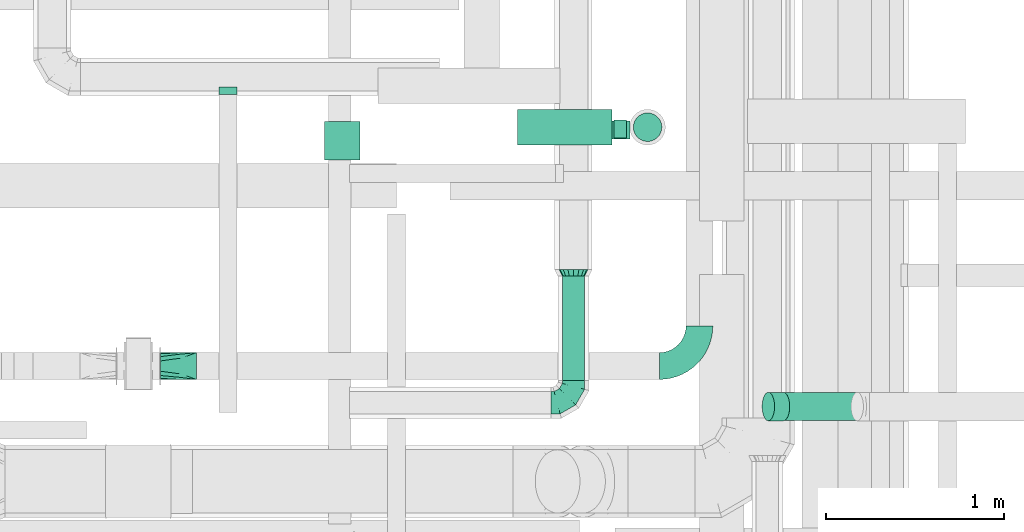
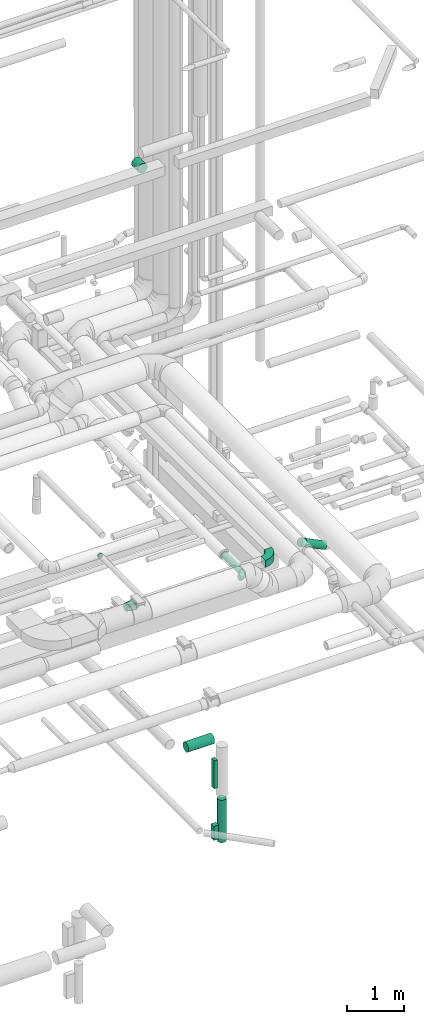
# One storey, part 213 of 337: 7 flow segments, 6 flow fittings.
"""IFC2X3 building model written with IfcOpenShell, lengths in millimetres."""

from ifc_helpers import new_model, entity, si_unit, converted_unit, derived_unit, direction, frame, frame_2d, origin, origin_2d_with_axis, place, context, subcontext, project, spatial, polyline, circle_curve, parameter, trimmed, segment, composite_curve, rectangle, circle, outline, extrude, faceted_brep, source, transform, mapped, material, type_object, type_shapes, element, save


model = new_model("IFC2X3")

# Units and contexts
model_context = context("Model", 3, precision=0.01, world=origin(), true_north=direction((6.12303176911189e-17, 1.0)))
body_context = subcontext(model_context, "Body", "Model", "MODEL_VIEW")
ifc_project = project(units=[si_unit("LENGTHUNIT", "METRE", prefix="MILLI"), si_unit("AREAUNIT", "SQUARE_METRE"), si_unit("VOLUMEUNIT", "CUBIC_METRE"), converted_unit("PLANEANGLEUNIT", "DEGREE", entity("IfcRatioMeasure", 0.0174532925199433), si_unit("PLANEANGLEUNIT", "RADIAN"), dimensions=[0, 0, 0, 0, 0, 0, 0]), si_unit("MASSUNIT", "GRAM", prefix="KILO"), derived_unit("MASSDENSITYUNIT", [(si_unit("MASSUNIT", "GRAM", prefix="KILO"), 1), (si_unit("LENGTHUNIT", "METRE"), -3)]), derived_unit("MOMENTOFINERTIAUNIT", [(si_unit("LENGTHUNIT", "METRE"), 4)]), si_unit("TIMEUNIT", "SECOND"), si_unit("FREQUENCYUNIT", "HERTZ"), si_unit("THERMODYNAMICTEMPERATUREUNIT", "DEGREE_CELSIUS"), derived_unit("THERMALTRANSMITTANCEUNIT", [(si_unit("MASSUNIT", "GRAM", prefix="KILO"), 1), (si_unit("THERMODYNAMICTEMPERATUREUNIT", "KELVIN"), -1), (si_unit("TIMEUNIT", "SECOND"), -3)]), derived_unit("VOLUMETRICFLOWRATEUNIT", [(si_unit("LENGTHUNIT", "METRE"), 3), (si_unit("TIMEUNIT", "SECOND"), -1)]), derived_unit("MASSFLOWRATEUNIT", [(si_unit("MASSUNIT", "GRAM", prefix="KILO"), 1), (si_unit("TIMEUNIT", "SECOND"), -1)]), derived_unit("ROTATIONALFREQUENCYUNIT", [(si_unit("TIMEUNIT", "SECOND"), -1)]), si_unit("ELECTRICCURRENTUNIT", "AMPERE"), si_unit("ELECTRICVOLTAGEUNIT", "VOLT"), si_unit("POWERUNIT", "WATT"), si_unit("FORCEUNIT", "NEWTON", prefix="KILO"), si_unit("ILLUMINANCEUNIT", "LUX"), si_unit("LUMINOUSFLUXUNIT", "LUMEN"), si_unit("LUMINOUSINTENSITYUNIT", "CANDELA"), derived_unit("USERDEFINED", [(si_unit("MASSUNIT", "GRAM", prefix="KILO"), -1), (si_unit("LENGTHUNIT", "METRE"), -2), (si_unit("TIMEUNIT", "SECOND"), 3), (si_unit("LUMINOUSFLUXUNIT", "LUMEN"), 1)]), derived_unit("LINEARVELOCITYUNIT", [(si_unit("LENGTHUNIT", "METRE"), 1), (si_unit("TIMEUNIT", "SECOND"), -1)]), si_unit("PRESSUREUNIT", "PASCAL"), derived_unit("USERDEFINED", [(si_unit("LENGTHUNIT", "METRE"), -2), (si_unit("MASSUNIT", "GRAM", prefix="KILO"), 1), (si_unit("TIMEUNIT", "SECOND"), -2)]), derived_unit("LINEARFORCEUNIT", [(si_unit("MASSUNIT", "GRAM", prefix="KILO"), 1), (si_unit("LENGTHUNIT", "METRE"), 1), (si_unit("TIMEUNIT", "SECOND"), -2), (si_unit("LENGTHUNIT", "METRE"), -1)]), derived_unit("PLANARFORCEUNIT", [(si_unit("MASSUNIT", "GRAM", prefix="KILO"), 1), (si_unit("LENGTHUNIT", "METRE"), 1), (si_unit("TIMEUNIT", "SECOND"), -2), (si_unit("LENGTHUNIT", "METRE"), -2)])], contexts=[model_context])

# Site, building, storey
site_placement = place(None, origin())
site = spatial("IfcSite", under=ifc_project, at=site_placement, CompositionType="ELEMENT")
building_placement = place(site_placement, origin())
building = spatial("IfcBuilding", under=site, at=building_placement, CompositionType="ELEMENT")
storey_placement = place(building_placement, origin())
storey = spatial("IfcBuildingStorey", under=building, at=storey_placement, CompositionType="ELEMENT", Elevation=0.0)

# Flow segments
duct_segment_type_1 = type_object("IfcDuctSegmentType", PredefinedType="NOTDEFINED")
flow_segment_1_placement = place(storey_placement, frame((64875.17, 5388.51, -2500.0)))
element("IfcFlowSegment", 1, at=flow_segment_1_placement, inside=storey, type_object=duct_segment_type_1, context=body_context, shape_type="SweptSolid", body=[
    extrude(rectangle(XDim=68.7960227245273, YDim=100.0, at=origin_2d_with_axis()), frame((34.4, 50.0, 0.0), z_axis=(0.0, 0.0, 1.0), x_axis=(-1.0, 0.0, 0.0)), (0.0, 0.0, 1.0), 600.0),
])
flow_segment_2_placement = place(storey_placement, frame((64864.08, 5383.51, -3600.0)))
element("IfcFlowSegment", 2, at=flow_segment_2_placement, inside=storey, type_object=duct_segment_type_1, context=body_context, shape_type="SweptSolid", body=[
    extrude(rectangle(XDim=100.800588892394, YDim=100.0, at=origin_2d_with_axis()), frame((50.4, 50.0, 0.0), z_axis=(0.0, 0.0, 1.0), x_axis=(-1.0, 0.0, 0.0)), (0.0, 0.0, 1.0), 300.0),
])
duct_segment_type_2 = type_object("IfcDuctSegmentType", PredefinedType="NOTDEFINED")
flow_segment_3_placement = place(storey_placement, frame((64333.78, 5346.85, -1551.6)))
element("IfcFlowSegment", 3, at=flow_segment_3_placement, inside=storey, type_object=duct_segment_type_2, context=body_context, shape_type="SweptSolid", body=[
    extrude(circle(Radius=100.0, at=origin_2d_with_axis()), frame((0.0, 101.6, 101.6), z_axis=(1.0, 0.0, 0.0), x_axis=(0.0, -1.0, 0.0)), (0.0, 0.0, 1.0), 529.688711010026),
])
flow_segment_4_placement = place(storey_placement, frame((64981.87, 5366.85, -3699.99)))
element("IfcFlowSegment", 4, at=flow_segment_4_placement, inside=storey, type_object=duct_segment_type_2, context=body_context, shape_type="SweptSolid", body=[
    extrude(circle(Radius=80.0, at=origin_2d_with_axis()), frame((81.6, 81.6, 0.0), z_axis=(0.0, 0.0, 1.0), x_axis=(0.0, 1.0, 0.0)), (0.0, 0.0, 1.0), 910.0),
])
flow_segment_5_placement = place(storey_placement, frame((64584.17, 4029.91, 2985.9)))
element("IfcFlowSegment", 5, at=flow_segment_5_placement, inside=storey, type_object=duct_segment_type_2, context=body_context, shape_type="SweptSolid", body=[
    extrude(circle(Radius=62.5, at=origin_2d_with_axis()), frame((64.1, 0.0, 64.1), z_axis=(0.0, 1.0, 0.0), x_axis=(-1.0, 0.0, 0.0)), (0.0, 0.0, 1.0), 585.000000000002),
])
flow_segment_6_placement = place(storey_placement, frame((63251.4, 5265.54, 11298.4)))
element("IfcFlowSegment", 6, at=flow_segment_6_placement, inside=storey, type_object=duct_segment_type_2, context=body_context, shape_type="SweptSolid", body=[
    extrude(circle(Radius=100.0, at=origin_2d_with_axis()), frame((101.6, 0.0, 101.6), z_axis=(0.0, 1.0, 0.0), x_axis=(-1.0, 0.0, 0.0)), (0.0, 0.0, 1.0), 214.999999999935),
])
flow_segment_7_placement = place(storey_placement, frame((65788.16, 3801.86, 3082.45)))
element("IfcFlowSegment", 7, at=flow_segment_7_placement, inside=storey, type_object=duct_segment_type_2, context=body_context, shape_type="SweptSolid", body=[
    extrude(circle(Radius=80.0, at=origin_2d_with_axis()), frame((449.69, 81.6, 73.58), z_axis=(-0.899810081682065, 0.0, 0.436281809044699), x_axis=(0.0, 1.0, 0.0)), (0.0, 0.0, 1.0), 459.201892014133),
])

# Flow fittings
ifc_material = material()
duct_fitting_type_1 = type_object("IfcDuctFittingType", PredefinedType="NOTDEFINED", material=ifc_material)
shared_shape_1 = source(origin(), body_context, "Body", "Brep", [
    faceted_brep([(-125.0, 0.0, -62.5), (-125.0, -16.18, -60.37), (-125.0, -31.25, -54.13), (-125.0, -44.19, -44.19), (-125.0, -54.13, -31.25), (-125.0, -60.37, -16.18), (-125.0, -62.5, 0.0), (-125.0, -60.37, 16.18), (-125.0, -54.13, 31.25), (-125.0, -44.19, 44.19), (-125.0, -31.25, 54.13), (-125.0, -16.18, 60.37), (-125.0, 0.0, 62.5), (-125.0, 16.18, 60.37), (-125.0, 31.25, 54.13), (-125.0, 44.19, 44.19), (-125.0, 54.13, 31.25), (-125.0, 60.37, 16.18), (-125.0, 62.5, 0.0), (-125.0, 60.37, -16.18), (-125.0, 54.13, -31.25), (-125.0, 44.19, -44.19), (-125.0, 31.25, -54.13), (-125.0, 16.18, -60.37), (-95.84, 16.18, 60.37), (-99.88, 31.25, 54.13), (-91.51, 0.0, 62.5), (-103.35, 44.19, 44.19), (-107.68, 60.37, 16.18), (-108.25, 62.5, 0.0), (-106.01, 54.13, 31.25), (-106.01, 54.13, -31.25), (-103.35, 44.19, -44.19), (-107.68, 60.37, -16.18), (-95.84, 16.18, -60.37), (-91.51, 0.0, -62.5), (-99.88, 31.25, -54.13), (-87.17, -16.18, -60.37), (-83.13, -31.25, -54.13), (-79.66, -44.19, -44.19), (-77.0, -54.13, -31.25), (-75.33, -60.37, -16.18), (-74.76, -62.5, 0.0), (-75.33, -60.37, 16.18), (-77.0, -54.13, 31.25), (-79.66, -44.19, 44.19), (-83.13, -31.25, 54.13), (-87.17, -16.18, 60.37), (-45.34, 45.34, 60.37), (-56.37, 56.37, 54.13), (-33.49, 33.49, 62.5), (-65.85, 65.85, 44.19), (-73.12, 73.12, 31.25), (-77.69, 77.69, 16.18), (-79.25, 79.25, 0.0), (-77.69, 77.69, -16.18), (-73.12, 73.12, -31.25), (-65.85, 65.85, -44.19), (-45.34, 45.34, -60.37), (-33.49, 33.49, -62.5), (-56.37, 56.37, -54.13), (-21.65, 21.65, -60.37), (-10.62, 10.62, -54.13), (-1.14, 1.14, -44.19), (6.13, -6.13, -31.25), (10.7, -10.7, -16.18), (12.26, -12.26, 0.0), (10.7, -10.7, 16.18), (6.13, -6.13, 31.25), (-1.14, 1.14, 44.19), (-10.62, 10.62, 54.13), (-21.65, 21.65, 60.37), (-16.18, 95.84, 60.37), (-31.25, 99.88, 54.13), (0.0, 91.51, 62.5), (-44.19, 103.35, 44.19), (-54.13, 106.01, 31.25), (-60.37, 107.68, 16.18), (-62.5, 108.25, 0.0), (-60.37, 107.68, -16.18), (-54.13, 106.01, -31.25), (-44.19, 103.35, -44.19), (-16.18, 95.84, -60.37), (0.0, 91.51, -62.5), (-31.25, 99.88, -54.13), (16.18, 87.17, -60.37), (31.25, 83.13, -54.13), (44.19, 79.66, -44.19), (54.13, 77.0, -31.25), (60.37, 75.33, -16.18), (62.5, 74.76, 0.0), (60.37, 75.33, 16.18), (54.13, 77.0, 31.25), (44.19, 79.66, 44.19), (31.25, 83.13, 54.13), (16.18, 87.17, 60.37), (-16.18, 125.0, -60.37), (-31.25, 125.0, -54.13), (-44.19, 125.0, -44.19), (-54.13, 125.0, -31.25), (-60.37, 125.0, -16.18), (-62.5, 125.0, 0.0), (-60.37, 125.0, 16.18), (-54.13, 125.0, 31.25), (-44.19, 125.0, 44.19), (-31.25, 125.0, 54.13), (-16.18, 125.0, 60.37), (0.0, 125.0, 62.5), (16.18, 125.0, 60.37), (31.25, 125.0, 54.13), (44.19, 125.0, 44.19), (54.13, 125.0, 31.25), (60.37, 125.0, 16.18), (62.5, 125.0, 0.0), (60.37, 125.0, -16.18), (54.13, 125.0, -31.25), (44.19, 125.0, -44.19), (31.25, 125.0, -54.13), (16.18, 125.0, -60.37), (0.0, 125.0, -62.5)], [[[0, 1, 2, 3, 4, 5, 6, 7, 8, 9, 10, 11, 12, 13, 14, 15, 16, 17, 18, 19, 20, 21, 22, 23]], [[24, 25, 14, 13]], [[26, 24, 13, 12]], [[14, 25, 27, 15]], [[28, 29, 18, 17]], [[30, 28, 17, 16]], [[15, 27, 30, 16]], [[20, 31, 32, 21]], [[33, 31, 20, 19]], [[18, 29, 33, 19]], [[34, 35, 0, 23]], [[36, 34, 23, 22]], [[21, 32, 36, 22]], [[1, 0, 35, 37]], [[2, 1, 37, 38]], [[38, 39, 3, 2]], [[5, 4, 40, 41]], [[6, 5, 41, 42]], [[39, 40, 4, 3]], [[6, 42, 43, 7]], [[7, 43, 44, 8]], [[45, 9, 8, 44]], [[9, 45, 46, 10]], [[10, 46, 47, 11]], [[26, 12, 11, 47]], [[48, 49, 25, 24]], [[50, 48, 24, 26]], [[27, 25, 49, 51]], [[52, 53, 28, 30]], [[51, 52, 30, 27]], [[29, 28, 53, 54]], [[55, 56, 31, 33]], [[54, 55, 33, 29]], [[57, 32, 31, 56]], [[58, 59, 35, 34]], [[60, 58, 34, 36]], [[57, 60, 36, 32]], [[37, 35, 59, 61]], [[38, 37, 61, 62]], [[39, 38, 62, 63]], [[41, 40, 64, 65]], [[42, 41, 65, 66]], [[63, 64, 40, 39]], [[43, 42, 66, 67]], [[44, 43, 67, 68]], [[68, 69, 45, 44]], [[46, 45, 69, 70]], [[47, 46, 70, 71]], [[26, 47, 71, 50]], [[72, 73, 49, 48]], [[74, 72, 48, 50]], [[51, 49, 73, 75]], [[76, 77, 53, 52]], [[75, 76, 52, 51]], [[54, 53, 77, 78]], [[79, 80, 56, 55]], [[78, 79, 55, 54]], [[81, 57, 56, 80]], [[82, 83, 59, 58]], [[84, 82, 58, 60]], [[81, 84, 60, 57]], [[61, 59, 83, 85]], [[62, 61, 85, 86]], [[63, 62, 86, 87]], [[65, 64, 88, 89]], [[66, 65, 89, 90]], [[87, 88, 64, 63]], [[67, 66, 90, 91]], [[68, 67, 91, 92]], [[92, 93, 69, 68]], [[70, 69, 93, 94]], [[71, 70, 94, 95]], [[50, 71, 95, 74]], [[96, 97, 98, 99, 100, 101, 102, 103, 104, 105, 106, 107, 108, 109, 110, 111, 112, 113, 114, 115, 116, 117, 118, 119]], [[72, 74, 107, 106]], [[73, 72, 106, 105]], [[75, 73, 105, 104]], [[77, 76, 103, 102]], [[78, 77, 102, 101]], [[75, 104, 103, 76]], [[78, 101, 100, 79]], [[79, 100, 99, 80]], [[80, 99, 98, 81]], [[96, 119, 83, 82]], [[97, 96, 82, 84]], [[84, 81, 98, 97]], [[83, 119, 118, 85]], [[85, 118, 117, 86]], [[116, 87, 86, 117]], [[88, 115, 114, 89]], [[89, 114, 113, 90]], [[115, 88, 87, 116]], [[91, 90, 113, 112]], [[92, 91, 112, 111]], [[111, 110, 93, 92]], [[95, 94, 109, 108]], [[74, 95, 108, 107]], [[110, 109, 94, 93]]]),
])
type_shapes(duct_fitting_type_1, [shared_shape_1])
flow_fitting_1_placement = place(storey_placement, frame((64648.27, 3904.91, 3050.0)))
element("IfcFlowFitting", 8, at=flow_fitting_1_placement, inside=storey, type_object=duct_fitting_type_1, material=ifc_material, context=body_context, shape_type="MappedRepresentation", body=[
    mapped(shared_shape_1, transform((0.0, 0.0, 0.0), scale=1.0)),
])
duct_fitting_type_2 = type_object("IfcDuctFittingType", PredefinedType="NOTDEFINED", material=ifc_material)
shared_shape_2 = source(origin(), body_context, "Body", "Brep", [
    faceted_brep([(20.0, 12.94, -48.3), (20.0, 25.0, -43.3), (20.0, 35.36, -35.36), (20.0, 43.3, -25.0), (20.0, 48.3, -12.94), (20.0, 50.0, 0.0), (20.0, 48.3, 12.94), (20.0, 43.3, 25.0), (20.0, 35.36, 35.36), (20.0, 25.0, 43.3), (20.0, 12.94, 48.3), (20.0, 0.0, 50.0), (20.0, -12.94, 48.3), (20.0, -25.0, 43.3), (20.0, -35.36, 35.36), (20.0, -43.3, 25.0), (20.0, -48.3, 12.94), (20.0, -50.0, 0.0), (20.0, -48.3, -12.94), (20.0, -43.3, -25.0), (20.0, -35.36, -35.36), (20.0, -25.0, -43.3), (20.0, -12.94, -48.3), (20.0, 0.0, -50.0), (0.0, 0.0, 50.0), (0.0, 12.94, 48.3), (-23.65, 12.94, 48.3), (-23.65, 0.0, 50.0), (0.0, 25.0, 43.3), (-23.65, 25.0, 43.3), (0.0, 35.36, 35.36), (-23.65, 35.36, 35.36), (0.0, 43.3, 25.0), (0.0, 48.3, 12.94), (-23.65, 48.3, 12.94), (-23.65, 43.3, 25.0), (0.0, 50.0, 0.0), (-23.65, 50.0, 0.0), (0.0, 48.3, -12.94), (-23.65, 48.3, -12.94), (0.0, 43.3, -25.0), (-23.65, 43.3, -25.0), (0.0, 35.36, -35.36), (-23.65, 35.36, -35.36), (0.0, 25.0, -43.3), (0.0, 12.94, -48.3), (-23.65, 12.94, -48.3), (-23.65, 25.0, -43.3), (0.0, 0.0, -50.0), (-23.65, 0.0, -50.0), (0.0, -12.94, -48.3), (-23.65, -12.94, -48.3), (0.0, -25.0, -43.3), (-23.65, -25.0, -43.3), (0.0, -35.36, -35.36), (-23.65, -35.36, -35.36), (0.0, -43.3, -25.0), (0.0, -48.3, -12.94), (-23.65, -48.3, -12.94), (-23.65, -43.3, -25.0), (0.0, -50.0, 0.0), (-23.65, -50.0, 0.0), (0.0, -48.3, 12.94), (-23.65, -48.3, 12.94), (0.0, -43.3, 25.0), (-23.65, -43.3, 25.0), (0.0, -35.36, 35.36), (-23.65, -35.36, 35.36), (0.0, -25.0, 43.3), (0.0, -12.94, 48.3), (-23.65, -12.94, 48.3), (-23.65, -25.0, 43.3)], [[[0, 1, 2, 3, 4, 5, 6, 7, 8, 9, 10, 11, 12, 13, 14, 15, 16, 17, 18, 19, 20, 21, 22, 23]], [[24, 11, 10, 25, 26, 27]], [[25, 10, 9, 28, 29, 26]], [[28, 9, 8, 30, 31, 29]], [[32, 7, 6, 33, 34, 35]], [[33, 6, 5, 36, 37, 34]], [[30, 8, 7, 32, 35, 31]], [[36, 5, 4, 38, 39, 37]], [[38, 4, 3, 40, 41, 39]], [[40, 3, 2, 42, 43, 41]], [[44, 1, 0, 45, 46, 47]], [[45, 0, 23, 48, 49, 46]], [[42, 2, 1, 44, 47, 43]], [[48, 23, 22, 50, 51, 49]], [[50, 22, 21, 52, 53, 51]], [[52, 21, 20, 54, 55, 53]], [[56, 19, 18, 57, 58, 59]], [[57, 18, 17, 60, 61, 58]], [[54, 20, 19, 56, 59, 55]], [[60, 17, 16, 62, 63, 61]], [[62, 16, 15, 64, 65, 63]], [[64, 15, 14, 66, 67, 65]], [[68, 13, 12, 69, 70, 71]], [[69, 12, 11, 24, 27, 70]], [[66, 14, 13, 68, 71, 67]], [[49, 51, 53, 55, 59, 58, 61, 63, 65, 67, 71, 70, 27, 26, 29, 31, 35, 34, 37, 39, 41, 43, 47, 46]]]),
])
type_shapes(duct_fitting_type_2, [shared_shape_2])
flow_fitting_2_placement = place(storey_placement, frame((62713.68, 5651.17, 3100.0), z_axis=(0.0, 0.0, -1.0), x_axis=(0.0, -1.0, 0.0)))
element("IfcFlowFitting", 9, at=flow_fitting_2_placement, inside=storey, type_object=duct_fitting_type_2, material=ifc_material, context=body_context, shape_type="MappedRepresentation", body=[
    mapped(shared_shape_2, transform((0.0, 0.0, 0.0), scale=1.0)),
])
duct_fitting_type_3 = type_object("IfcDuctFittingType", PredefinedType="NOTDEFINED", material=ifc_material)
shared_shape_3 = source(origin(), body_context, "Body", "Brep", [
    faceted_brep([(35.0, 0.0, -80.0), (35.0, 12.81, -77.45), (35.0, 30.61, -73.91), (35.0, 43.59, -65.24), (35.0, 56.57, -56.57), (35.0, 65.24, -43.59), (35.0, 73.91, -30.61), (35.0, 76.96, -15.31), (35.0, 80.0, 0.0), (35.0, 77.45, 12.81), (35.0, 73.91, 30.61), (35.0, 65.24, 43.59), (35.0, 56.57, 56.57), (35.0, 43.59, 65.24), (35.0, 30.61, 73.91), (35.0, 15.31, 76.96), (35.0, 0.0, 80.0), (35.0, -12.81, 77.45), (35.0, -30.61, 73.91), (35.0, -43.59, 65.24), (35.0, -56.57, 56.57), (35.0, -65.24, 43.59), (35.0, -73.91, 30.61), (35.0, -76.96, 15.31), (35.0, -80.0, 0.0), (35.0, -77.45, -12.81), (35.0, -73.91, -30.61), (35.0, -65.24, -43.59), (35.0, -56.57, -56.57), (35.0, -43.59, -65.24), (35.0, -30.61, -73.91), (35.0, -15.31, -76.96), (0.0, -23.92, -57.74), (0.0, -34.06, -50.97), (0.0, -44.19, -44.19), (0.0, -50.97, -34.06), (0.0, -57.74, -23.92), (0.0, -60.12, -11.96), (0.0, -62.5, 0.0), (0.0, -60.12, 11.96), (0.0, -57.74, 23.92), (0.0, -50.97, 34.06), (0.0, -44.19, 44.19), (0.0, -34.06, 50.97), (0.0, -23.92, 57.74), (0.0, -11.96, 60.12), (0.0, 0.0, 62.5), (0.0, 11.96, 60.12), (0.0, 23.92, 57.74), (0.0, 34.06, 50.97), (0.0, 44.19, 44.19), (0.0, 50.97, 34.06), (0.0, 57.74, 23.92), (0.0, 60.12, 11.96), (0.0, 62.5, 0.0), (0.0, 60.12, -11.96), (0.0, 57.74, -23.92), (0.0, 50.97, -34.06), (0.0, 44.19, -44.19), (0.0, 34.06, -50.97), (0.0, 23.92, -57.74), (0.0, 11.96, -60.12), (0.0, 0.0, -62.5), (0.0, -11.96, -60.12)], [[[0, 1, 2, 3, 4, 5, 6, 7, 8, 9, 10, 11, 12, 13, 14, 15, 16, 17, 18, 19, 20, 21, 22, 23, 24, 25, 26, 27, 28, 29, 30, 31]], [[32, 33, 34, 35, 36, 37, 38, 39, 40, 41, 42, 43, 44, 45, 46, 47, 48, 49, 50, 51, 52, 53, 54, 55, 56, 57, 58, 59, 60, 61, 62, 63]], [[10, 9, 8, 54, 53, 52]], [[11, 10, 52, 51, 50, 12]], [[48, 14, 13, 12, 50, 49]], [[46, 16, 15, 14, 48, 47]], [[18, 17, 16, 46, 45, 44]], [[19, 18, 44, 43, 42, 20]], [[40, 22, 21, 20, 42, 41]], [[38, 24, 23, 22, 40, 39]], [[26, 25, 24, 38, 37, 36]], [[27, 26, 36, 35, 34, 28]], [[32, 30, 29, 28, 34, 33]], [[62, 0, 31, 30, 32, 63]], [[2, 1, 0, 62, 61, 60]], [[3, 2, 60, 59, 58, 4]], [[56, 6, 5, 4, 58, 57]], [[54, 8, 7, 6, 56, 55]]]),
])
type_shapes(duct_fitting_type_3, [shared_shape_3])
flow_fitting_3_placement = place(storey_placement, frame((64648.27, 4614.91, 3050.0), z_axis=(0.0, 0.0, 1.0), x_axis=(0.0, 1.0, 0.0)))
element("IfcFlowFitting", 10, at=flow_fitting_3_placement, inside=storey, type_object=duct_fitting_type_3, material=ifc_material, context=body_context, shape_type="MappedRepresentation", body=[
    mapped(shared_shape_3, transform((0.0, 0.0, 0.0), scale=1.0)),
])
duct_fitting_type_4 = type_object("IfcDuctFittingType", PredefinedType="NOTDEFINED", material=ifc_material)
shared_shape_4 = source(origin(), body_context, "Body", "Brep", [
    faceted_brep([(20.0, 20.71, -77.27), (20.0, 40.0, -69.28), (20.0, 56.57, -56.57), (20.0, 69.28, -40.0), (20.0, 77.27, -20.71), (20.0, 80.0, 0.0), (20.0, 77.27, 20.71), (20.0, 69.28, 40.0), (20.0, 56.57, 56.57), (20.0, 40.0, 69.28), (20.0, 20.71, 77.27), (20.0, 0.0, 80.0), (20.0, -20.71, 77.27), (20.0, -40.0, 69.28), (20.0, -56.57, 56.57), (20.0, -69.28, 40.0), (20.0, -77.27, 20.71), (20.0, -80.0, 0.0), (20.0, -77.27, -20.71), (20.0, -69.28, -40.0), (20.0, -56.57, -56.57), (20.0, -40.0, -69.28), (20.0, -20.71, -77.27), (20.0, 0.0, -80.0), (0.0, 0.0, 80.0), (0.0, 20.71, 77.27), (-73.9, 20.71, 77.27), (-73.9, 0.0, 80.0), (0.0, 40.0, 69.28), (-73.9, 40.0, 69.28), (0.0, 56.57, 56.57), (-73.9, 56.57, 56.57), (0.0, 69.28, 40.0), (0.0, 77.27, 20.71), (-73.9, 77.27, 20.71), (-73.9, 69.28, 40.0), (0.0, 80.0, 0.0), (-73.9, 80.0, 0.0), (0.0, 77.27, -20.71), (-73.9, 77.27, -20.71), (0.0, 69.28, -40.0), (-73.9, 69.28, -40.0), (0.0, 56.57, -56.57), (-73.9, 56.57, -56.57), (0.0, 40.0, -69.28), (0.0, 20.71, -77.27), (-73.9, 20.71, -77.27), (-73.9, 40.0, -69.28), (0.0, 0.0, -80.0), (-73.9, 0.0, -80.0), (0.0, -20.71, -77.27), (-73.9, -20.71, -77.27), (0.0, -40.0, -69.28), (-73.9, -40.0, -69.28), (0.0, -56.57, -56.57), (-73.9, -56.57, -56.57), (0.0, -69.28, -40.0), (0.0, -77.27, -20.71), (-73.9, -77.27, -20.71), (-73.9, -69.28, -40.0), (0.0, -80.0, 0.0), (-73.9, -80.0, 0.0), (0.0, -77.27, 20.71), (-73.9, -77.27, 20.71), (0.0, -69.28, 40.0), (-73.9, -69.28, 40.0), (0.0, -56.57, 56.57), (-73.9, -56.57, 56.57), (0.0, -40.0, 69.28), (0.0, -20.71, 77.27), (-73.9, -20.71, 77.27), (-73.9, -40.0, 69.28)], [[[0, 1, 2, 3, 4, 5, 6, 7, 8, 9, 10, 11, 12, 13, 14, 15, 16, 17, 18, 19, 20, 21, 22, 23]], [[24, 11, 10, 25, 26, 27]], [[25, 10, 9, 28, 29, 26]], [[28, 9, 8, 30, 31, 29]], [[32, 7, 6, 33, 34, 35]], [[33, 6, 5, 36, 37, 34]], [[30, 8, 7, 32, 35, 31]], [[36, 5, 4, 38, 39, 37]], [[38, 4, 3, 40, 41, 39]], [[40, 3, 2, 42, 43, 41]], [[44, 1, 0, 45, 46, 47]], [[45, 0, 23, 48, 49, 46]], [[42, 2, 1, 44, 47, 43]], [[48, 23, 22, 50, 51, 49]], [[50, 22, 21, 52, 53, 51]], [[52, 21, 20, 54, 55, 53]], [[56, 19, 18, 57, 58, 59]], [[57, 18, 17, 60, 61, 58]], [[54, 20, 19, 56, 59, 55]], [[60, 17, 16, 62, 63, 61]], [[62, 16, 15, 64, 65, 63]], [[64, 15, 14, 66, 67, 65]], [[68, 13, 12, 69, 70, 71]], [[69, 12, 11, 24, 27, 70]], [[66, 14, 13, 68, 71, 67]], [[49, 51, 53, 55, 59, 58, 61, 63, 65, 67, 71, 70, 27, 26, 29, 31, 35, 34, 37, 39, 41, 43, 47, 46]]]),
])
type_shapes(duct_fitting_type_4, [shared_shape_4])
flow_fitting_4_placement = place(storey_placement, frame((65806.66, 3883.46, 3365.1), z_axis=(-0.436281809044716, 0.0, -0.899810081682057), x_axis=(0.899810081682057, 0.0, -0.436281809044716)))
element("IfcFlowFitting", 11, at=flow_fitting_4_placement, inside=storey, type_object=duct_fitting_type_4, material=ifc_material, context=body_context, shape_type="MappedRepresentation", body=[
    mapped(shared_shape_4, transform((0.0, 0.0, 0.0), scale=1.0)),
])
duct_fitting_type_5 = type_object("IfcDuctFittingType", PredefinedType="NOTDEFINED", material=ifc_material)
shared_shape_5 = source(origin(), body_context, "Body", "Brep", [
    faceted_brep([(200.0, 53.03, 53.03), (200.0, 46.95, 57.1), (200.0, 40.87, 61.16), (200.0, 34.78, 65.23), (200.0, 28.7, 69.29), (200.0, 21.44, 70.74), (200.0, 14.17, 72.18), (200.0, 10.63, 72.89), (200.0, 7.09, 73.59), (200.0, 0.0, 75.0), (200.0, -7.09, 73.59), (200.0, -14.17, 72.18), (200.0, -17.81, 71.46), (200.0, -21.44, 70.74), (200.0, -28.7, 69.29), (200.0, -34.78, 65.23), (200.0, -40.87, 61.16), (200.0, -46.95, 57.1), (200.0, -53.03, 53.03), (200.0, -57.1, 46.95), (200.0, -61.16, 40.87), (200.0, -65.23, 34.78), (200.0, -69.29, 28.7), (200.0, -70.74, 21.44), (200.0, -72.18, 14.17), (200.0, -72.89, 10.63), (200.0, -73.59, 7.09), (200.0, -75.0, 0.0), (200.0, -73.59, -7.09), (200.0, -72.18, -14.17), (200.0, -71.46, -17.81), (200.0, -70.74, -21.44), (200.0, -69.29, -28.7), (200.0, -65.23, -34.78), (200.0, -61.16, -40.87), (200.0, -57.1, -46.95), (200.0, -53.03, -53.03), (200.0, -46.95, -57.1), (200.0, -40.87, -61.16), (200.0, -34.78, -65.23), (200.0, -28.7, -69.29), (200.0, -21.44, -70.74), (200.0, -14.17, -72.18), (200.0, -10.63, -72.89), (200.0, -7.09, -73.59), (200.0, 0.0, -75.0), (200.0, 7.09, -73.59), (200.0, 14.17, -72.18), (200.0, 17.81, -71.46), (200.0, 21.44, -70.74), (200.0, 28.7, -69.29), (200.0, 34.78, -65.23), (200.0, 40.87, -61.16), (200.0, 46.95, -57.1), (200.0, 53.03, -53.03), (200.0, 57.1, -46.95), (200.0, 61.16, -40.87), (200.0, 65.23, -34.78), (200.0, 69.29, -28.7), (200.0, 70.74, -21.44), (200.0, 72.18, -14.17), (200.0, 72.89, -10.63), (200.0, 73.59, -7.09), (200.0, 75.0, 0.0), (200.0, 73.59, 7.09), (200.0, 72.18, 14.17), (200.0, 71.46, 17.81), (200.0, 70.74, 21.44), (200.0, 69.29, 28.7), (200.0, 65.23, 34.78), (200.0, 61.16, 40.87), (200.0, 57.1, 46.95), (0.0, -75.0, 75.0), (0.0, 75.0, 75.0), (0.0, 75.0, -75.0), (0.0, -75.0, -75.0), (52.06, -55.48, 75.0), (78.09, -45.72, 75.0), (176.03, -8.99, 75.0), (152.06, -17.98, 75.0), (128.09, -26.97, 75.0), (104.11, -35.96, 75.0), (100.0, -65.57, 62.36), (78.09, -75.0, 45.72), (104.11, -75.0, 35.96), (128.09, -75.0, 26.97), (152.06, -75.0, 17.98), (164.04, -75.0, 13.48), (176.03, -75.0, 8.99), (26.03, -75.0, 65.24), (52.06, -75.0, 55.48), (26.03, -65.24, 75.0), (26.03, -75.0, -65.24), (52.06, -75.0, -55.48), (78.09, -75.0, -45.72), (104.11, -75.0, -35.96), (128.09, -75.0, -26.97), (152.06, -75.0, -17.98), (176.03, -75.0, -8.99), (100.0, -62.36, -65.57), (78.09, -45.72, -75.0), (104.11, -35.96, -75.0), (128.09, -26.97, -75.0), (152.06, -17.98, -75.0), (164.04, -13.48, -75.0), (176.03, -8.99, -75.0), (26.03, -65.24, -75.0), (52.06, -55.48, -75.0), (26.03, 65.24, -75.0), (52.06, 55.48, -75.0), (78.09, 45.72, -75.0), (104.11, 35.96, -75.0), (128.09, 26.97, -75.0), (152.06, 17.98, -75.0), (176.03, 8.99, -75.0), (100.0, 65.57, -62.36), (78.09, 75.0, -45.72), (104.11, 75.0, -35.96), (128.09, 75.0, -26.97), (152.06, 75.0, -17.98), (164.04, 75.0, -13.48), (176.03, 75.0, -8.99), (26.03, 75.0, -65.24), (52.06, 75.0, -55.48), (26.03, 75.0, 65.24), (52.06, 75.0, 55.48), (78.09, 75.0, 45.72), (104.11, 75.0, 35.96), (128.09, 75.0, 26.97), (152.06, 75.0, 17.98), (176.03, 75.0, 8.99), (100.0, 62.36, 65.57), (78.09, 45.72, 75.0), (104.11, 35.96, 75.0), (128.09, 26.97, 75.0), (152.06, 17.98, 75.0), (164.04, 13.48, 75.0), (176.03, 8.99, 75.0), (26.03, 65.24, 75.0), (52.06, 55.48, 75.0)], [[[0, 1, 2, 3, 4, 5, 6, 7, 8, 9, 10, 11, 12, 13, 14, 15, 16, 17, 18, 19, 20, 21, 22, 23, 24, 25, 26, 27, 28, 29, 30, 31, 32, 33, 34, 35, 36, 37, 38, 39, 40, 41, 42, 43, 44, 45, 46, 47, 48, 49, 50, 51, 52, 53, 54, 55, 56, 57, 58, 59, 60, 61, 62, 63, 64, 65, 66, 67, 68, 69, 70, 71]], [[72, 73, 74, 75]], [[76, 16, 77]], [[16, 15, 14, 77]], [[78, 79, 80, 81, 77, 14, 13, 12, 11, 10, 9]], [[17, 82, 18]], [[24, 23, 22, 83, 84, 85, 86, 87, 88, 27, 26, 25]], [[82, 72, 89]], [[82, 19, 18]], [[83, 20, 90]], [[91, 72, 82]], [[22, 21, 20, 83]], [[90, 20, 19]], [[19, 82, 89]], [[90, 19, 89]], [[76, 17, 16]], [[17, 76, 91]], [[82, 17, 91]], [[88, 87, 86, 85, 84, 83, 90, 89, 72, 75, 92, 93, 94, 95, 96, 97, 98, 27]], [[93, 34, 94]], [[34, 33, 32, 94]], [[98, 97, 96, 95, 94, 32, 31, 30, 29, 28, 27]], [[35, 99, 36]], [[42, 41, 40, 100, 101, 102, 103, 104, 105, 45, 44, 43]], [[99, 75, 106]], [[99, 37, 36]], [[100, 38, 107]], [[92, 75, 99]], [[40, 39, 38, 100]], [[107, 38, 37]], [[37, 99, 106]], [[107, 37, 106]], [[93, 35, 34]], [[35, 93, 92]], [[99, 35, 92]], [[105, 104, 103, 102, 101, 100, 107, 106, 75, 74, 108, 109, 110, 111, 112, 113, 114, 45]], [[109, 52, 110]], [[52, 51, 50, 110]], [[114, 113, 112, 111, 110, 50, 49, 48, 47, 46, 45]], [[53, 115, 54]], [[60, 59, 58, 116, 117, 118, 119, 120, 121, 63, 62, 61]], [[115, 74, 122]], [[115, 55, 54]], [[116, 56, 123]], [[108, 74, 115]], [[58, 57, 56, 116]], [[123, 56, 55]], [[55, 115, 122]], [[123, 55, 122]], [[109, 53, 52]], [[53, 109, 108]], [[115, 53, 108]], [[74, 73, 124, 125, 126, 127, 128, 129, 130, 63, 121, 120, 119, 118, 117, 116, 123, 122]], [[125, 70, 126]], [[70, 69, 68, 126]], [[130, 129, 128, 127, 126, 68, 67, 66, 65, 64, 63]], [[71, 131, 0]], [[6, 5, 4, 132, 133, 134, 135, 136, 137, 9, 8, 7]], [[131, 73, 138]], [[131, 1, 0]], [[132, 2, 139]], [[124, 73, 131]], [[4, 3, 2, 132]], [[139, 2, 1]], [[1, 131, 138]], [[139, 1, 138]], [[125, 71, 70]], [[71, 125, 124]], [[131, 71, 124]], [[73, 72, 91, 76, 77, 81, 80, 79, 78, 9, 137, 136, 135, 134, 133, 132, 139, 138]]]),
])
type_shapes(duct_fitting_type_5, [shared_shape_5])
flow_fitting_5_placement = place(storey_placement, frame((62535.0, 4110.29, 3050.0), z_axis=(0.0, 0.0, 1.0), x_axis=(-1.0, 0.0, 0.0)))
element("IfcFlowFitting", 12, at=flow_fitting_5_placement, inside=storey, type_object=duct_fitting_type_5, material=ifc_material, context=body_context, shape_type="MappedRepresentation", body=[
    mapped(shared_shape_5, transform((0.0, 0.0, 0.0), scale=1.0)),
])
duct_fitting_type_6 = type_object("IfcDuctFittingType", PredefinedType="NOTDEFINED", material=ifc_material)
shared_shape_6 = source(origin(), body_context, "Body", "SweptSolid", [
    extrude(outline(composite_curve([segment(polyline([(-187.5, -112.5), (-37.5, -112.5)]), True, "CONTINUOUS"), segment(trimmed(circle_curve(frame_2d((112.5, -112.5), x_axis=(0.0, 1.0)), 150.0), [parameter(0.0)], [parameter(90.0000000000001)], True, "PARAMETER"), False, "CONTINUOUS"), segment(polyline([(112.5, 37.5), (112.5, 187.5)]), True, "CONTINUOUS"), segment(trimmed(circle_curve(frame_2d((112.5, -112.5), x_axis=(0.0, 1.0)), 300.0), [parameter(0.0)], [parameter(90.0000000000001)], True, "PARAMETER"), True, "CONTINUOUS")], self_intersect=False)), frame((-112.5, 112.5, -75.0), z_axis=(0.0, 0.0, 1.0), x_axis=(-1.0, 0.0, 0.0)), (0.0, 0.0, 1.0), 150.0),
])
type_shapes(duct_fitting_type_6, [shared_shape_6])
flow_fitting_6_placement = place(storey_placement, frame((65354.05, 4110.29, 3050.0)))
element("IfcFlowFitting", 13, at=flow_fitting_6_placement, inside=storey, type_object=duct_fitting_type_6, material=ifc_material, context=body_context, shape_type="MappedRepresentation", body=[
    mapped(shared_shape_6, transform((0.0, 0.0, 0.0), scale=1.0)),
])

save(model, "model.ifc")
